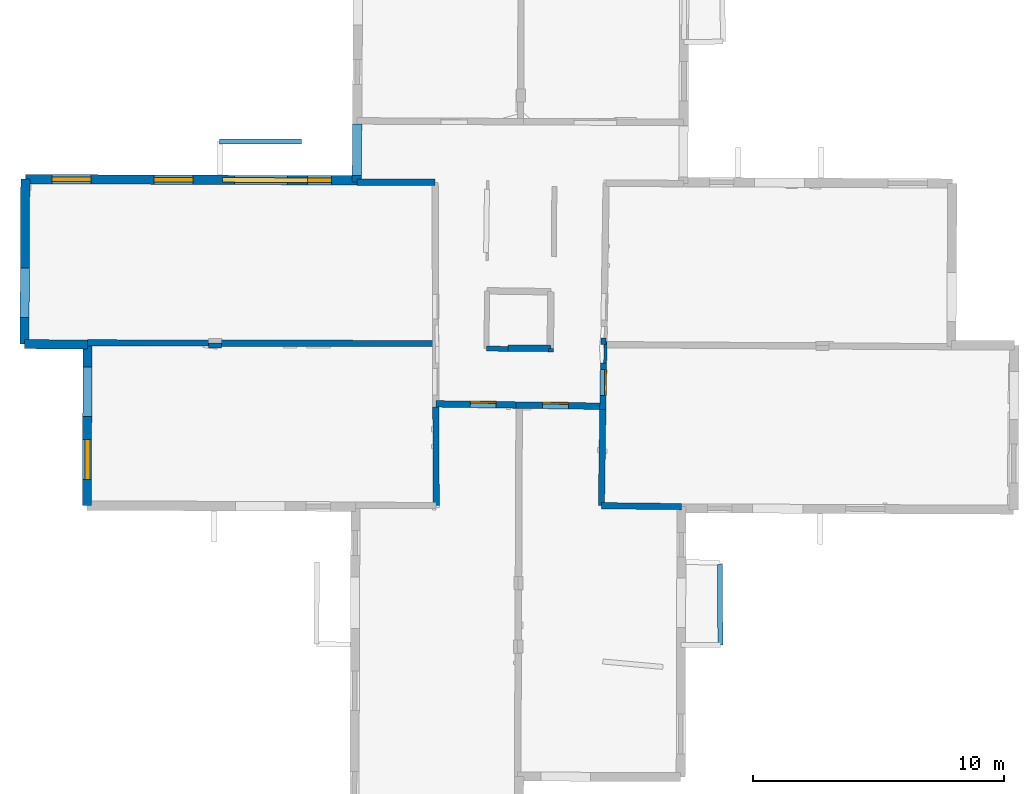
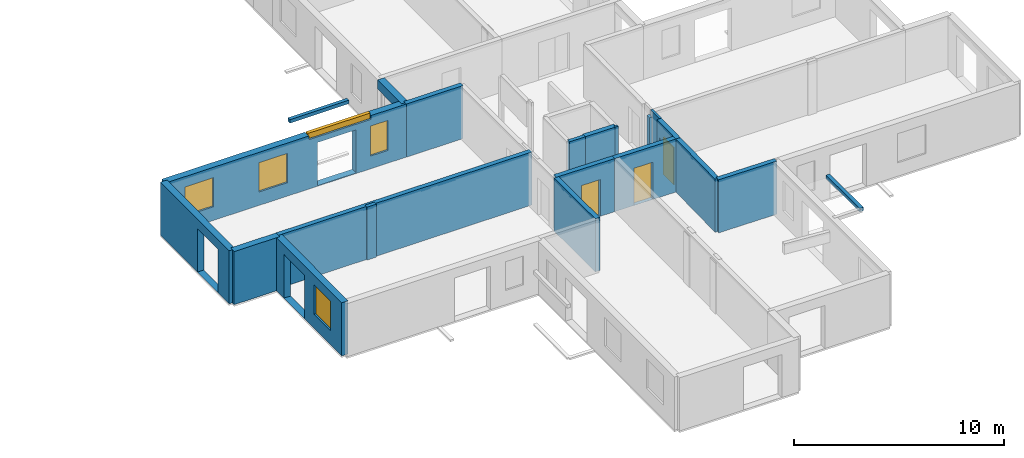
# One storey, part 4 of 15: 21 walls, 5 windows, 3 doors, 12 openings.
"""IFC2X3 building model written with IfcOpenShell, lengths in metres."""

from ifc_helpers import new_model, entity, si_unit, converted_unit, derived_unit, direction, frame, frame_2d, origin, origin_2d_with_axis, place, context, subcontext, project, spatial, polyline, rectangle, outline, extrude, source, transform, mapped, material, layer, layer_set, layer_usage, type_object, type_shapes, element, fill, save


model = new_model("IFC2X3")

# Units and contexts
model_context = context("Model", 3, precision=1e-05, world=origin(), true_north=direction((0.0, 1.0)))
body_context = subcontext(model_context, "Body", "Model", "MODEL_VIEW")
ifc_project = project(units=[si_unit("LENGTHUNIT", "METRE"), si_unit("AREAUNIT", "SQUARE_METRE"), si_unit("VOLUMEUNIT", "CUBIC_METRE"), converted_unit("PLANEANGLEUNIT", "DEGREE", entity("IfcRatioMeasure", 0.0174532925199433), si_unit("PLANEANGLEUNIT", "RADIAN"), dimensions=[0, 0, 0, 0, 0, 0, 0]), si_unit("MASSUNIT", "GRAM", prefix="KILO"), derived_unit("MASSDENSITYUNIT", [(si_unit("MASSUNIT", "GRAM", prefix="KILO"), 1), (si_unit("LENGTHUNIT", "METRE"), -3)]), derived_unit("MOMENTOFINERTIAUNIT", [(si_unit("LENGTHUNIT", "METRE"), 4)]), si_unit("TIMEUNIT", "SECOND"), si_unit("FREQUENCYUNIT", "HERTZ"), si_unit("THERMODYNAMICTEMPERATUREUNIT", "DEGREE_CELSIUS"), derived_unit("THERMALTRANSMITTANCEUNIT", [(si_unit("MASSUNIT", "GRAM", prefix="KILO"), 1), (si_unit("THERMODYNAMICTEMPERATUREUNIT", "KELVIN"), -1), (si_unit("TIMEUNIT", "SECOND"), -3)]), derived_unit("VOLUMETRICFLOWRATEUNIT", [(si_unit("LENGTHUNIT", "METRE"), 3), (si_unit("TIMEUNIT", "SECOND"), -1)]), si_unit("ELECTRICCURRENTUNIT", "AMPERE"), si_unit("ELECTRICVOLTAGEUNIT", "VOLT"), si_unit("POWERUNIT", "WATT"), si_unit("FORCEUNIT", "NEWTON", prefix="KILO"), si_unit("ILLUMINANCEUNIT", "LUX"), si_unit("LUMINOUSFLUXUNIT", "LUMEN"), si_unit("LUMINOUSINTENSITYUNIT", "CANDELA"), derived_unit("USERDEFINED", [(si_unit("MASSUNIT", "GRAM", prefix="KILO"), -1), (si_unit("LENGTHUNIT", "METRE"), -2), (si_unit("TIMEUNIT", "SECOND"), 3), (si_unit("LUMINOUSFLUXUNIT", "LUMEN"), 1)]), derived_unit("LINEARVELOCITYUNIT", [(si_unit("LENGTHUNIT", "METRE"), 1), (si_unit("TIMEUNIT", "SECOND"), -1)]), si_unit("PRESSUREUNIT", "PASCAL"), derived_unit("USERDEFINED", [(si_unit("LENGTHUNIT", "METRE"), -2), (si_unit("MASSUNIT", "GRAM", prefix="KILO"), 1), (si_unit("TIMEUNIT", "SECOND"), -2)]), derived_unit("LINEARFORCEUNIT", [(si_unit("MASSUNIT", "GRAM", prefix="KILO"), 1), (si_unit("LENGTHUNIT", "METRE"), 1), (si_unit("TIMEUNIT", "SECOND"), -2), (si_unit("LENGTHUNIT", "METRE"), -1)]), derived_unit("PLANARFORCEUNIT", [(si_unit("MASSUNIT", "GRAM", prefix="KILO"), 1), (si_unit("LENGTHUNIT", "METRE"), 1), (si_unit("TIMEUNIT", "SECOND"), -2), (si_unit("LENGTHUNIT", "METRE"), -2)])], contexts=[model_context])

# Site, building, storey
placement_1 = place(None, origin())
site = spatial("IfcSite", under=ifc_project, at=placement_1, CompositionType="ELEMENT")
building = spatial("IfcBuilding", under=site, at=placement_1, CompositionType="ELEMENT")
storey_placement = place(placement_1, frame((0.0, 0.0, 2.3807327747345)))
storey = spatial("IfcBuildingStorey", under=building, at=storey_placement, Name="Level 2", CompositionType="ELEMENT", Elevation=2.3807327747345)

# Wall, opening, door
ifc_material_1 = material(Name="Default wall")
ifc_layer_1 = layer(ifc_material_1, 0.25)
ifc_layer_set_1 = layer_set([ifc_layer_1], Name="wall_thickness_0.2500")
ifc_layer_usage_1 = layer_usage(ifc_layer_set_1, "AXIS2", "POSITIVE", -0.125)
wall_type_1 = type_object("IfcWallType", Name="wall_thickness_0.2500", PredefinedType="STANDARD", material=ifc_layer_set_1)
wall_1_placement = place(storey_placement, frame((9.53301218270894, 18.6953074827152, 0.0), z_axis=(0.0, 0.0, 1.0), x_axis=(-0.0145011206617014, -0.999894853221855, 0.0)))
wall_1 = element("IfcWallStandardCase", 1, at=wall_1_placement, inside=storey, type_object=wall_type_1, material=ifc_layer_usage_1, Name="Wall:740", ObjectType="Wall", context=body_context, shape_type="SweptSolid", body=[
    extrude(outline(polyline([(1.84873564836269, -0.125), (1.84873564836269, 0.125), (0.0, 0.125), (0.0, -0.125), (1.84873564836269, -0.125)])), origin(), (0.0, 0.0, 1.0), 3.08589615821838),
])
opening_1_placement = place(wall_1_placement, frame((0.260006625357022, -0.125, 0.00526785850524902)))
opening_1 = element("IfcOpeningElement", 2, at=opening_1_placement, cuts=wall_1, Name="Opening : 1025 x 2160 : 475", ObjectType="Opening", context=body_context, shape_type="SweptSolid", body=[
    extrude(rectangle(XDim=1.025, YDim=2.16, at=frame_2d((1.08, 0.5125), x_axis=(0.0, 1.0))), frame((0.0, 0.0, 0.0), z_axis=(0.0, 1.0, 0.0), x_axis=(0.0, 0.0, 1.0)), (0.0, 0.0, 1.0), 0.25),
])
ifc_material_2 = material(Name="Door Panel")
door_style_1 = type_object("IfcDoorStyle", Name="Door : 1025 x 2160mm", ConstructionType="NOTDEFINED", OperationType="SINGLE_SWING_RIGHT", ParameterTakesPrecedence=False, Sizeable=False, material=ifc_material_2)
shared_shape_1 = source(origin(), body_context, "Body", "SweptSolid", [
    extrude(rectangle(XDim=0.0625, YDim=1.025, at=origin_2d_with_axis()), frame((0.5125, 0.21875, 0.0), z_axis=(0.0, 0.0, 1.0), x_axis=(0.0, 1.0, 0.0)), (0.0, 0.0, 1.0), 2.16),
])
type_shapes(door_style_1, [shared_shape_1])
door_1_placement = place(opening_1_placement, origin())
door_1 = element("IfcDoor", 3, at=door_1_placement, inside=storey, type_object=door_style_1, Name="Door : 1025 x 2160mm : 91", ObjectType="Door : 1025 x 2160mm", OverallHeight=2.16, OverallWidth=1.025, context=body_context, shape_type="MappedRepresentation", body=[
    mapped(shared_shape_1, transform((0.0, 0.0, 0.0), scale=1.0)),
])
fill(opening_1, door_1)

# Walls
wall_2_placement = place(storey_placement, frame((9.50620344400044, 16.8467662229496, 0.0), z_axis=(0.0, 0.0, 1.0), x_axis=(-0.0145013094081497, -0.999894850484514, 0.0)))
element("IfcWallStandardCase", 4, at=wall_2_placement, inside=storey, type_object=wall_type_1, material=ifc_layer_usage_1, Name="Wall:741", ObjectType="Wall", context=body_context, shape_type="SweptSolid", body=[
    extrude(outline(polyline([(3.82704540208208, -0.125), (3.82704540208208, 0.125), (0.0, 0.125), (0.0, -0.125), (3.82704540208208, -0.125)])), origin(), (0.0, 0.0, 1.0), 3.08589615821838),
])
wall_3_placement = place(storey_placement, frame((2.86248065747801, 16.9407368492508, 0.0), z_axis=(0.0, 0.0, 1.0), x_axis=(0.00334221755554105, -0.999994414775308, 0.0)))
element("IfcWallStandardCase", 5, at=wall_3_placement, inside=storey, type_object=wall_type_1, material=ifc_layer_usage_1, Name="Wall:751", ObjectType="Wall", context=body_context, shape_type="SweptSolid", body=[
    extrude(outline(polyline([(3.91631597140505, -0.125), (3.91631597140505, 0.125), (0.0, 0.125), (0.0, -0.125), (3.91631597140505, -0.125)])), origin(), (0.0, 0.0, 1.0), 3.08589615821838),
])
wall_4_placement = place(storey_placement, frame((9.45070600739901, 13.0201234646556, 0.0), z_axis=(0.0, 0.0, 1.0), x_axis=(0.999931198168241, -0.0117302570230344, 0.0)))
element("IfcWallStandardCase", 6, at=wall_4_placement, inside=storey, type_object=wall_type_1, material=ifc_layer_usage_1, Name="Wall:759", ObjectType="Wall", context=body_context, shape_type="SweptSolid", body=[
    extrude(outline(polyline([(3.18486096234184, -0.125), (3.18486096234184, 0.125), (0.0, 0.125), (0.0, -0.125), (3.18486096234184, -0.125)])), origin(), (0.0, 0.0, 1.0), 3.08589615821838),
])
wall_5_placement = place(storey_placement, frame((-10.9931703634592, 19.5004155220706, 0.0), z_axis=(0.0, 0.0, 1.0), x_axis=(0.999997760825852, -0.00211620964969585, 0.0)))
element("IfcWallStandardCase", 7, at=wall_5_placement, inside=storey, type_object=wall_type_1, material=ifc_layer_usage_1, Name="Wall:808", ObjectType="Wall", context=body_context, shape_type="SweptSolid", body=[
    extrude(outline(polyline([(13.9017158894102, -0.125), (13.9017158894102, 0.125), (0.0, 0.125), (0.0, -0.125), (13.9017158894102, -0.125)])), origin(), (0.0, 0.0, 1.0), 3.08589615821838),
])
ifc_layer_2 = layer(ifc_material_1, 0.2)
ifc_layer_set_2 = layer_set([ifc_layer_2], Name="wall_thickness_0.2000")
ifc_layer_usage_2 = layer_usage(ifc_layer_set_2, "AXIS2", "POSITIVE", -0.1)
wall_type_2 = type_object("IfcWallType", Name="wall_thickness_0.2000", PredefinedType="STANDARD", material=ifc_layer_set_2)
wall_6_placement = place(storey_placement, frame((9.52954024406511, 19.6908299720356, 0.0), z_axis=(0.0, 0.0, 1.0), x_axis=(-0.0165806385920283, -0.999862531763182, 0.0)))
element("IfcWallStandardCase", 8, at=wall_6_placement, inside=storey, type_object=wall_type_2, material=ifc_layer_usage_2, Name="Wall:731", ObjectType="Wall", context=body_context, shape_type="SweptSolid", body=[
    extrude(outline(polyline([(0.263084337737113, -0.1), (0.263084337737113, 0.1), (0.0, 0.1), (0.0, -0.1), (0.263084337737113, -0.1)])), origin(), (0.0, 0.0, 1.0), 2.73026776313782),
])
placement_2 = place(placement_1, frame((0.0, 0.0, 5.26399993896484)))
wall_7_placement = place(placement_2, frame((-5.73608958530563, 27.5107986496355, 0.0), z_axis=(0.0, 0.0, 1.0), x_axis=(0.999996231489754, 0.00274536086709242, 0.0)))
element("IfcWallStandardCase", 9, at=wall_7_placement, inside=storey, type_object=wall_type_2, material=ifc_layer_usage_2, Name="Wall:748", ObjectType="Wall", context=body_context, shape_type="SweptSolid", body=[
    extrude(outline(polyline([(3.25630890610755, -0.1), (3.25630890610755, 0.1), (0.0, 0.1), (0.0, -0.1), (3.25630890610755, -0.1)])), origin(), (0.0, 0.0, 1.0), 0.202628993988037),
])
wall_8_placement = place(storey_placement, frame((4.87166485657516, 19.2711542141516, 0.0), z_axis=(0.0, 0.0, 1.0), x_axis=(0.999925632187604, -0.0121954948329237, 0.0)))
element("IfcWallStandardCase", 10, at=wall_8_placement, inside=storey, type_object=wall_type_2, material=ifc_layer_usage_2, Name="Wall:779", ObjectType="Wall", context=body_context, shape_type="SweptSolid", body=[
    extrude(outline(polyline([(0.867851424519787, -0.1), (0.867851424519787, 0.1), (0.0, 0.1), (0.0, -0.1), (0.867851424519787, -0.1)])), origin(), (0.0, 0.0, 1.0), 3.08589615821838),
])
placement_3 = place(placement_1, frame((0.0, 0.0, 5.26399993896484)))
wall_9_placement = place(placement_3, frame((14.1666712061143, 10.6849880773365, 0.0), z_axis=(0.0, 0.0, 1.0), x_axis=(0.00473088606756421, -0.999988809295892, 0.0)))
element("IfcWallStandardCase", 11, at=wall_9_placement, inside=storey, type_object=wall_type_2, material=ifc_layer_usage_2, Name="Wall:789", ObjectType="Wall", context=body_context, shape_type="SweptSolid", body=[
    extrude(outline(polyline([(3.20277794110223, -0.1), (3.20277794110223, 0.1), (0.0, 0.1), (0.0, -0.1), (3.20277794110223, -0.1)])), origin(), (0.0, 0.0, 1.0), 0.202628993988037),
])
wall_10_placement = place(storey_placement, frame((7.44933189598537, 19.2738002505562, 0.0), z_axis=(0.0, 0.0, 1.0), x_axis=(-0.0117520865905171, -0.99993094184587, 0.0)))
element("IfcWallStandardCase", 12, at=wall_10_placement, inside=storey, type_object=wall_type_2, material=ifc_layer_usage_2, Name="Wall:819", ObjectType="Wall", context=body_context, shape_type="SweptSolid", body=[
    extrude(outline(polyline([(0.131137367261747, -0.1), (0.131137367261747, 0.1), (0.0, 0.1), (0.0, -0.1), (0.131137367261747, -0.1)])), origin(), (0.0, 0.0, 1.0), 3.08589615821838),
])
wall_11_placement = place(storey_placement, frame((-6.18510954226567, 19.3989009980014, 0.0), z_axis=(0.0, 0.0, 1.0), x_axis=(0.999984864049039, 0.00550196990403891, 0.0)))
element("IfcWallStandardCase", 13, at=wall_11_placement, inside=storey, type_object=wall_type_2, material=ifc_layer_usage_2, Name="Wall:822", ObjectType="Wall", context=body_context, shape_type="SweptSolid", body=[
    extrude(outline(polyline([(0.51999974538547, -0.1), (0.51999974538547, 0.1), (0.0, 0.1), (0.0, -0.1), (0.51999974538547, -0.1)])), origin(), (0.0, 0.0, 1.0), 3.08589615821838),
])
ifc_layer_3 = layer(ifc_material_1, 0.259999990463257)
ifc_layer_set_3 = layer_set([ifc_layer_3], Name="wall_thickness_0.2600")
ifc_layer_usage_3 = layer_usage(ifc_layer_set_3, "AXIS2", "POSITIVE", -0.129999995231628)
wall_type_3 = type_object("IfcWallType", Name="wall_thickness_0.2600", PredefinedType="STANDARD", material=ifc_layer_set_3)
wall_12_placement = place(storey_placement, frame((5.73994076918062, 19.2935029759409, 0.0), z_axis=(0.0, 0.0, 1.0), x_axis=(0.999933579152415, -0.0115255057780813, 0.0)))
element("IfcWallStandardCase", 14, at=wall_12_placement, inside=storey, type_object=wall_type_3, material=ifc_layer_usage_3, Name="Wall:758", ObjectType="Wall", context=body_context, shape_type="SweptSolid", body=[
    extrude(outline(polyline([(1.7095051407135, -0.129999995231628), (1.7095051407135, 0.129999995231628), (0.0, 0.129999995231628), (0.0, -0.129999995231628), (1.7095051407135, -0.129999995231628)])), origin(), (0.0, 0.0, 1.0), 3.08589615821838),
])
wall_13_placement = place(storey_placement, frame((-0.282822123891786, 25.8986741312719, 0.0), z_axis=(0.0, 0.0, 1.0), x_axis=(0.999992651087245, -0.00383376727293302, 0.0)))
element("IfcWallStandardCase", 15, at=wall_13_placement, inside=storey, type_object=wall_type_3, material=ifc_layer_usage_3, Name="Wall:804", ObjectType="Wall", context=body_context, shape_type="SweptSolid", body=[
    extrude(outline(polyline([(3.11542571271789, -0.129999995231628), (3.11542571271789, 0.129999995231628), (0.0, 0.129999995231628), (0.0, -0.129999995231628), (3.11542571271789, -0.129999995231628)])), origin(), (0.0, 0.0, 1.0), 3.08589615821838),
])

# Wall, opening, door
wall_14_placement = place(storey_placement, frame((2.86204582705376, 17.0707161455043, 0.0), z_axis=(0.0, 0.0, 1.0), x_axis=(0.999900070977063, -0.0141367627151342, 0.0)))
wall_14 = element("IfcWallStandardCase", 16, at=wall_14_placement, inside=storey, type_object=wall_type_3, material=ifc_layer_usage_3, Name="Wall:835", ObjectType="Wall", context=body_context, shape_type="SweptSolid", body=[
    extrude(outline(polyline([(3.18535401488082, -0.129999995231628), (3.18535401488082, 0.129999995231628), (0.0, 0.129999995231628), (0.0, -0.129999995231628), (3.18535401488082, -0.129999995231628)])), origin(), (0.0, 0.0, 1.0), 3.08589615821838),
])
opening_2_placement = place(wall_14_placement, frame((1.36965371742109, -0.129999995231628, 0.00526785850524902)))
opening_2 = element("IfcOpeningElement", 17, at=opening_2_placement, cuts=wall_14, Name="Opening : 1030 x 2130 : 529", ObjectType="Opening", context=body_context, shape_type="SweptSolid", body=[
    extrude(rectangle(XDim=1.03, YDim=2.13, at=frame_2d((1.065, 0.515), x_axis=(0.0, 1.0))), frame((0.0, 0.0, 0.0), z_axis=(0.0, 1.0, 0.0), x_axis=(0.0, 0.0, 1.0)), (0.0, 0.0, 1.0), 0.259999990463257),
])
door_style_2 = type_object("IfcDoorStyle", Name="Door : 1030 x 2130mm", ConstructionType="NOTDEFINED", OperationType="SINGLE_SWING_RIGHT", ParameterTakesPrecedence=False, Sizeable=False, material=ifc_material_2)
shared_shape_2 = source(origin(), body_context, "Body", "SweptSolid", [
    extrude(rectangle(XDim=0.0649999976158142, YDim=1.03, at=origin_2d_with_axis()), frame((0.515, 0.22749999165535, 0.0), z_axis=(0.0, 0.0, 1.0), x_axis=(0.0, 1.0, 0.0)), (0.0, 0.0, 1.0), 2.13),
])
type_shapes(door_style_2, [shared_shape_2])
door_2_placement = place(opening_2_placement, origin())
door_2 = element("IfcDoor", 18, at=door_2_placement, inside=storey, type_object=door_style_2, Name="Door : 1030 x 2130mm : 99", ObjectType="Door : 1030 x 2130mm", OverallHeight=2.13, OverallWidth=1.03, context=body_context, shape_type="MappedRepresentation", body=[
    mapped(shared_shape_2, transform((0.0, 0.0, 0.0), scale=1.0)),
])
fill(opening_2, door_2)

wall_15_placement = place(storey_placement, frame((6.04708153262017, 17.0256855516322, 0.0), z_axis=(0.0, 0.0, 1.0), x_axis=(0.999900068078504, -0.0141369677301611, 0.0)))
wall_15 = element("IfcWallStandardCase", 19, at=wall_15_placement, inside=storey, type_object=wall_type_3, material=ifc_layer_usage_3, Name="Wall:836", ObjectType="Wall", context=body_context, shape_type="SweptSolid", body=[
    extrude(outline(polyline([(3.46135254099834, -0.129999995231628), (3.46135254099834, 0.129999995231628), (0.0, 0.129999995231628), (0.0, -0.129999995231628), (3.46135254099834, -0.129999995231628)])), origin(), (0.0, 0.0, 1.0), 3.08589615821838),
])
opening_3_placement = place(wall_15_placement, frame((1.0642982046951, -0.129999995231628, 0.00526785850524902)))
opening_3 = element("IfcOpeningElement", 20, at=opening_3_placement, cuts=wall_15, Name="Opening : 1030 x 2160 : 530", ObjectType="Opening", context=body_context, shape_type="SweptSolid", body=[
    extrude(rectangle(XDim=1.03, YDim=2.16, at=frame_2d((1.08, 0.515), x_axis=(0.0, 1.0))), frame((0.0, 0.0, 0.0), z_axis=(0.0, 1.0, 0.0), x_axis=(0.0, 0.0, 1.0)), (0.0, 0.0, 1.0), 0.259999990463257),
])
door_style_3 = type_object("IfcDoorStyle", Name="Door : 1030 x 2160mm", ConstructionType="NOTDEFINED", OperationType="SINGLE_SWING_RIGHT", ParameterTakesPrecedence=False, Sizeable=False, material=ifc_material_2)
shared_shape_3 = source(origin(), body_context, "Body", "SweptSolid", [
    extrude(rectangle(XDim=0.0649999976158142, YDim=1.03, at=origin_2d_with_axis()), frame((0.515, 0.22749999165535, 0.0), z_axis=(0.0, 0.0, 1.0), x_axis=(0.0, 1.0, 0.0)), (0.0, 0.0, 1.0), 2.16),
])
type_shapes(door_style_3, [shared_shape_3])
door_3_placement = place(opening_3_placement, origin())
door_3 = element("IfcDoor", 21, at=door_3_placement, inside=storey, type_object=door_style_3, Name="Door : 1030 x 2160mm : 100", ObjectType="Door : 1030 x 2160mm", OverallHeight=2.16, OverallWidth=1.03, context=body_context, shape_type="MappedRepresentation", body=[
    mapped(shared_shape_3, transform((0.0, 0.0, 0.0), scale=1.0)),
])
fill(opening_3, door_3)

# Wall
ifc_layer_4 = layer(ifc_material_1, 0.119999997317791)
ifc_layer_set_4 = layer_set([ifc_layer_4], Name="wall_thickness_0.1200")
ifc_layer_usage_4 = layer_usage(ifc_layer_set_4, "AXIS2", "POSITIVE", -0.0599999986588955)
wall_type_4 = type_object("IfcWallType", Name="wall_thickness_0.1200", PredefinedType="STANDARD", material=ifc_layer_set_4)
wall_16_placement = place(storey_placement, frame((9.61685630867251, 19.5514369837292, 0.0), z_axis=(0.0, 0.0, 1.0), x_axis=(-0.0193977132626451, -0.99981184665925, 0.0)))
element("IfcWallStandardCase", 22, at=wall_16_placement, inside=storey, type_object=wall_type_4, material=ifc_layer_usage_4, Name="Wall:772", ObjectType="Wall", context=body_context, shape_type="SweptSolid", body=[
    extrude(outline(polyline([(0.856982304264175, -0.0599999986588955), (0.856982304264175, 0.0599999986588955), (0.0, 0.0599999986588955), (0.0, -0.0599999986588955), (0.856982304264175, -0.0599999986588955)])), origin(), (0.0, 0.0, 1.0), 3.08589615821838),
])

# Wall, openings, windows
ifc_layer_5 = layer(ifc_material_1, 0.370000004768372)
ifc_layer_set_5 = layer_set([ifc_layer_5], Name="wall_thickness_0.3700")
ifc_layer_usage_5 = layer_usage(ifc_layer_set_5, "AXIS2", "POSITIVE", -0.185000002384186)
wall_type_5 = type_object("IfcWallType", Name="wall_thickness_0.3700", PredefinedType="STANDARD", material=ifc_layer_set_5)
wall_17_placement = place(storey_placement, frame((-13.472029365922, 26.0140007582906, 0.0), z_axis=(0.0, 0.0, 1.0), x_axis=(0.999992672278282, -0.00382823585235349, 0.0)))
wall_17 = element("IfcWallStandardCase", 23, at=wall_17_placement, inside=storey, type_object=wall_type_5, material=ifc_layer_usage_5, Name="Wall:730", ObjectType="Wall", context=body_context, shape_type="SweptSolid", body=[
    extrude(outline(polyline([(13.1896890118208, -0.185000002384186), (13.1896890118208, 0.185000002384186), (0.0, 0.185000002384186), (0.0, -0.185000002384186), (13.1896890118208, -0.185000002384186)])), origin(), (0.0, 0.0, 1.0), 3.08589615821838),
])
opening_4_placement = place(wall_17_placement, frame((8.32822087555997, -0.185000002384186, 0.0342671871185303)))
element("IfcOpeningElement", 24, at=opening_4_placement, cuts=wall_17, Name="Opening : 2110 x 2510 : 466", ObjectType="Opening", context=body_context, shape_type="SweptSolid", body=[
    extrude(rectangle(XDim=2.11, YDim=2.51, at=frame_2d((1.255, 1.055), x_axis=(0.0, 1.0))), frame((0.0, 0.0, 0.0), z_axis=(0.0, 1.0, 0.0), x_axis=(0.0, 0.0, 1.0)), (0.0, 0.0, 1.0), 0.370000004768372),
])
opening_5_placement = place(wall_17_placement, frame((1.06382390083316, -0.185000002384186, 0.790267705917358)))
opening_5 = element("IfcOpeningElement", 25, at=opening_5_placement, cuts=wall_17, Name="Opening : 1555 x 1695 : 467", ObjectType="Opening", context=body_context, shape_type="SweptSolid", body=[
    extrude(rectangle(XDim=1.555, YDim=1.695, at=frame_2d((0.8475, 0.7775), x_axis=(0.0, 1.0))), frame((0.0, 0.0, 0.0), z_axis=(0.0, 1.0, 0.0), x_axis=(0.0, 0.0, 1.0)), (0.0, 0.0, 1.0), 0.370000004768372),
])
opening_6_placement = place(wall_17_placement, frame((5.11382420677952, -0.185000002384186, 0.780267715454102)))
opening_6 = element("IfcOpeningElement", 26, at=opening_6_placement, cuts=wall_17, Name="Opening : 1550 x 1705 : 468", ObjectType="Opening", context=body_context, shape_type="SweptSolid", body=[
    extrude(rectangle(XDim=1.55, YDim=1.705, at=frame_2d((0.8525, 0.775), x_axis=(0.0, 1.0))), frame((0.0, 0.0, 0.0), z_axis=(0.0, 1.0, 0.0), x_axis=(0.0, 0.0, 1.0)), (0.0, 0.0, 1.0), 0.370000004768372),
])
opening_7_placement = place(wall_17_placement, frame((7.84186437774535, -0.185000002384186, 2.8652675151825)))
opening_7 = element("IfcOpeningElement", 27, at=opening_7_placement, cuts=wall_17, Name="Opening : 3420 x 310 : 469", ObjectType="Opening", context=body_context, shape_type="SweptSolid", body=[
    extrude(rectangle(XDim=3.42, YDim=0.31, at=frame_2d((0.155, 1.71), x_axis=(0.0, 1.0))), frame((0.0, 0.0, 0.0), z_axis=(0.0, 1.0, 0.0), x_axis=(0.0, 0.0, 1.0)), (0.0, 0.0, 1.0), 0.370000004768372),
])
opening_8_placement = place(wall_17_placement, frame((11.2188260437975, -0.185000002384186, 0.740267753601074)))
opening_8 = element("IfcOpeningElement", 28, at=opening_8_placement, cuts=wall_17, Name="Opening : 955 x 1745 : 470", ObjectType="Opening", context=body_context, shape_type="SweptSolid", body=[
    extrude(rectangle(XDim=0.955, YDim=1.745, at=frame_2d((0.8725, 0.4775), x_axis=(0.0, 1.0))), frame((0.0, 0.0, 0.0), z_axis=(0.0, 1.0, 0.0), x_axis=(0.0, 0.0, 1.0)), (0.0, 0.0, 1.0), 0.370000004768372),
])
ifc_material_3 = material(Name="Window Default")
window_style_1 = type_object("IfcWindowStyle", Name="Window : 1555 x 1695mm", ConstructionType="NOTDEFINED", OperationType="NOTDEFINED", ParameterTakesPrecedence=False, Sizeable=False, material=ifc_material_3)
shared_shape_4 = source(origin(), body_context, "Body", "SweptSolid", [
    extrude(rectangle(XDim=0.185000002384186, YDim=1.555, at=origin_2d_with_axis()), frame((0.7775, 0.185000002384186, 0.0), z_axis=(0.0, 0.0, 1.0), x_axis=(0.0, 1.0, 0.0)), (0.0, 0.0, 1.0), 1.695),
])
type_shapes(window_style_1, [shared_shape_4])
window_1_placement = place(opening_5_placement, origin())
window_1 = element("IfcWindow", 29, at=window_1_placement, inside=storey, type_object=window_style_1, Name="Window : 1555 x 1695mm : 254", ObjectType="Window : 1555 x 1695mm", OverallHeight=1.695, OverallWidth=1.555, context=body_context, shape_type="MappedRepresentation", body=[
    mapped(shared_shape_4, transform((0.0, 0.0, 0.0), scale=1.0)),
])
fill(opening_5, window_1)
window_style_2 = type_object("IfcWindowStyle", Name="Window : 1550 x 1705mm", ConstructionType="NOTDEFINED", OperationType="NOTDEFINED", ParameterTakesPrecedence=False, Sizeable=False, material=ifc_material_3)
shared_shape_5 = source(origin(), body_context, "Body", "SweptSolid", [
    extrude(rectangle(XDim=0.185000002384186, YDim=1.55, at=origin_2d_with_axis()), frame((0.775, 0.185000002384186, 0.0), z_axis=(0.0, 0.0, 1.0), x_axis=(0.0, 1.0, 0.0)), (0.0, 0.0, 1.0), 1.705),
])
type_shapes(window_style_2, [shared_shape_5])
window_2_placement = place(opening_6_placement, origin())
window_2 = element("IfcWindow", 30, at=window_2_placement, inside=storey, type_object=window_style_2, Name="Window : 1550 x 1705mm : 255", ObjectType="Window : 1550 x 1705mm", OverallHeight=1.705, OverallWidth=1.55, context=body_context, shape_type="MappedRepresentation", body=[
    mapped(shared_shape_5, transform((0.0, 0.0, 0.0), scale=1.0)),
])
fill(opening_6, window_2)
window_style_3 = type_object("IfcWindowStyle", Name="Window : 3420 x 310mm", ConstructionType="NOTDEFINED", OperationType="NOTDEFINED", ParameterTakesPrecedence=False, Sizeable=False, material=ifc_material_3)
shared_shape_6 = source(origin(), body_context, "Body", "SweptSolid", [
    extrude(rectangle(XDim=0.185000002384186, YDim=3.42, at=origin_2d_with_axis()), frame((1.71, 0.185000002384186, 0.0), z_axis=(0.0, 0.0, 1.0), x_axis=(0.0, 1.0, 0.0)), (0.0, 0.0, 1.0), 0.31),
])
type_shapes(window_style_3, [shared_shape_6])
window_3_placement = place(opening_7_placement, origin())
window_3 = element("IfcWindow", 31, at=window_3_placement, inside=storey, type_object=window_style_3, Name="Window : 3420 x 310mm : 256", ObjectType="Window : 3420 x 310mm", OverallHeight=0.31, OverallWidth=3.42, context=body_context, shape_type="MappedRepresentation", body=[
    mapped(shared_shape_6, transform((0.0, 0.0, 0.0), scale=1.0)),
])
fill(opening_7, window_3)
window_style_4 = type_object("IfcWindowStyle", Name="Window : 955 x 1745mm", ConstructionType="NOTDEFINED", OperationType="NOTDEFINED", ParameterTakesPrecedence=False, Sizeable=False, material=ifc_material_3)
shared_shape_7 = source(origin(), body_context, "Body", "SweptSolid", [
    extrude(rectangle(XDim=0.185000002384186, YDim=0.955, at=origin_2d_with_axis()), frame((0.4775, 0.185000002384186, 0.0), z_axis=(0.0, 0.0, 1.0), x_axis=(0.0, 1.0, 0.0)), (0.0, 0.0, 1.0), 1.745),
])
type_shapes(window_style_4, [shared_shape_7])
window_4_placement = place(opening_8_placement, origin())
window_4 = element("IfcWindow", 32, at=window_4_placement, inside=storey, type_object=window_style_4, Name="Window : 955 x 1745mm : 257", ObjectType="Window : 955 x 1745mm", OverallHeight=1.745, OverallWidth=0.955, context=body_context, shape_type="MappedRepresentation", body=[
    mapped(shared_shape_7, transform((0.0, 0.0, 0.0), scale=1.0)),
])
fill(opening_8, window_4)

# Wall, opening
wall_18_placement = place(storey_placement, frame((-0.269213215052916, 28.2001199435259, 0.0), z_axis=(0.0, 0.0, 1.0), x_axis=(-0.00591293550141214, -0.999982518444076, 0.0)))
wall_18 = element("IfcWallStandardCase", 33, at=wall_18_placement, inside=storey, type_object=wall_type_5, material=ifc_layer_usage_5, Name="Wall:787", ObjectType="Wall", context=body_context, shape_type="SweptSolid", body=[
    extrude(outline(polyline([(2.30148714824914, -0.185000002384186), (2.30148714824914, 0.185000002384186), (0.0, 0.185000002384186), (0.0, -0.185000002384186), (2.30148714824914, -0.185000002384186)])), origin(), (0.0, 0.0, 1.0), 3.08589615821838),
])
opening_9_placement = place(wall_18_placement, frame((-0.000379569197382684, -0.185000002384186, 0.00526785850524902)))
element("IfcOpeningElement", 34, at=opening_9_placement, cuts=wall_18, Name="Opening : 2050 x 2535 : 501", ObjectType="Opening", context=body_context, shape_type="SweptSolid", body=[
    extrude(rectangle(XDim=2.05, YDim=2.535, at=frame_2d((1.2675, 1.025), x_axis=(0.0, 1.0))), frame((0.0, 0.0, 0.0), z_axis=(0.0, 1.0, 0.0), x_axis=(0.0, 0.0, 1.0)), (0.0, 0.0, 1.0), 0.370000004768372),
])

# Wall, openings, window
ifc_layer_6 = layer(ifc_material_1, 0.360000014305115)
ifc_layer_set_6 = layer_set([ifc_layer_6], Name="wall_thickness_0.3600")
ifc_layer_usage_6 = layer_usage(ifc_layer_set_6, "AXIS2", "POSITIVE", -0.180000007152557)
wall_type_6 = type_object("IfcWallType", Name="wall_thickness_0.3600", PredefinedType="STANDARD", material=ifc_layer_set_6)
wall_19_placement = place(storey_placement, frame((-10.9931693111803, 19.5004182214715, 0.0), z_axis=(0.0, 0.0, 1.0), x_axis=(-0.00481860201906959, -0.9999883904699, 0.0)))
wall_19 = element("IfcWallStandardCase", 35, at=wall_19_placement, inside=storey, type_object=wall_type_6, material=ifc_layer_usage_6, Name="Wall:746", ObjectType="Wall", context=body_context, shape_type="SweptSolid", body=[
    extrude(outline(polyline([(6.47677311404535, -0.180000007152557), (6.47677311404535, 0.180000007152557), (0.0, 0.180000007152557), (0.0, -0.180000007152557), (6.47677311404535, -0.180000007152557)])), origin(), (0.0, 0.0, 1.0), 3.08589615821838),
])
opening_10_placement = place(wall_19_placement, frame((0.953780773032799, -0.180000007152557, 0.00526785850524902)))
element("IfcOpeningElement", 36, at=opening_10_placement, cuts=wall_19, Name="Opening : 1985 x 2535 : 479", ObjectType="Opening", context=body_context, shape_type="SweptSolid", body=[
    extrude(rectangle(XDim=1.985, YDim=2.535, at=frame_2d((1.2675, 0.9925), x_axis=(0.0, 1.0))), frame((0.0, 0.0, 0.0), z_axis=(0.0, 1.0, 0.0), x_axis=(0.0, 0.0, 1.0)), (0.0, 0.0, 1.0), 0.360000014305115),
])
opening_11_placement = place(wall_19_placement, frame((3.84878050590389, -0.180000007152557, 0.830267667770386)))
opening_11 = element("IfcOpeningElement", 37, at=opening_11_placement, cuts=wall_19, Name="Opening : 1590 x 1710 : 480", ObjectType="Opening", context=body_context, shape_type="SweptSolid", body=[
    extrude(rectangle(XDim=1.59, YDim=1.71, at=frame_2d((0.855, 0.795), x_axis=(0.0, 1.0))), frame((0.0, 0.0, 0.0), z_axis=(0.0, 1.0, 0.0), x_axis=(0.0, 0.0, 1.0)), (0.0, 0.0, 1.0), 0.360000014305115),
])
window_style_5 = type_object("IfcWindowStyle", Name="Window : 1590 x 1710mm", ConstructionType="NOTDEFINED", OperationType="NOTDEFINED", ParameterTakesPrecedence=False, Sizeable=False, material=ifc_material_3)
shared_shape_8 = source(origin(), body_context, "Body", "SweptSolid", [
    extrude(rectangle(XDim=0.194999992847443, YDim=1.59, at=origin_2d_with_axis()), frame((0.795, 0.194999992847443, 0.0), z_axis=(0.0, 0.0, 1.0), x_axis=(0.0, 1.0, 0.0)), (0.0, 0.0, 1.0), 1.71),
])
type_shapes(window_style_5, [shared_shape_8])
window_5_placement = place(opening_11_placement, origin())
window_5 = element("IfcWindow", 38, at=window_5_placement, inside=storey, type_object=window_style_5, Name="Window : 1590 x 1710mm : 260", ObjectType="Window : 1590 x 1710mm", OverallHeight=1.71, OverallWidth=1.59, context=body_context, shape_type="MappedRepresentation", body=[
    mapped(shared_shape_8, transform((0.0, 0.0, 0.0), scale=1.0)),
])
fill(opening_11, window_5)

# Wall, opening
wall_20_placement = place(storey_placement, frame((-13.4720272608507, 26.0139982727616, 0.0), z_axis=(0.0, 0.0, 1.0), x_axis=(-0.00476686530411624, -0.999988638433044, 0.0)))
wall_20 = element("IfcWallStandardCase", 39, at=wall_20_placement, inside=storey, type_object=wall_type_6, material=ifc_layer_usage_6, Name="Wall:755", ObjectType="Wall", context=body_context, shape_type="SweptSolid", body=[
    extrude(outline(polyline([(6.56747459544005, -0.180000007152557), (6.56747459544005, 0.180000007152557), (0.0, 0.180000007152557), (0.0, -0.180000007152557), (6.56747459544005, -0.180000007152557)])), origin(), (0.0, 0.0, 1.0), 3.08589615821838),
])
opening_12_placement = place(wall_20_placement, frame((3.53034784936552, -0.180000007152557, 0.00526785850524902)))
element("IfcOpeningElement", 40, at=opening_12_placement, cuts=wall_20, Name="Opening : 1970 x 2535 : 483", ObjectType="Opening", context=body_context, shape_type="SweptSolid", body=[
    extrude(rectangle(XDim=1.97, YDim=2.535, at=frame_2d((1.2675, 0.985), x_axis=(0.0, 1.0))), frame((0.0, 0.0, 0.0), z_axis=(0.0, 1.0, 0.0), x_axis=(0.0, 0.0, 1.0)), (0.0, 0.0, 1.0), 0.360000014305115),
])

# Wall
wall_21_placement = place(storey_placement, frame((-13.5033338873235, 19.4465983989017, 0.0), z_axis=(0.0, 0.0, 1.0), x_axis=(0.999992981885847, -0.00374648889644399, 0.0)))
element("IfcWallStandardCase", 41, at=wall_21_placement, inside=storey, type_object=wall_type_6, material=ifc_layer_usage_6, Name="Wall:820", ObjectType="Wall", context=body_context, shape_type="SweptSolid", body=[
    extrude(outline(polyline([(2.5098776533652, -0.180000007152557), (2.5098776533652, 0.180000007152557), (0.0, 0.180000007152557), (0.0, -0.180000007152557), (2.5098776533652, -0.180000007152557)])), origin(), (0.0, 0.0, 1.0), 3.08589615821838),
])

save(model, "model.ifc")
